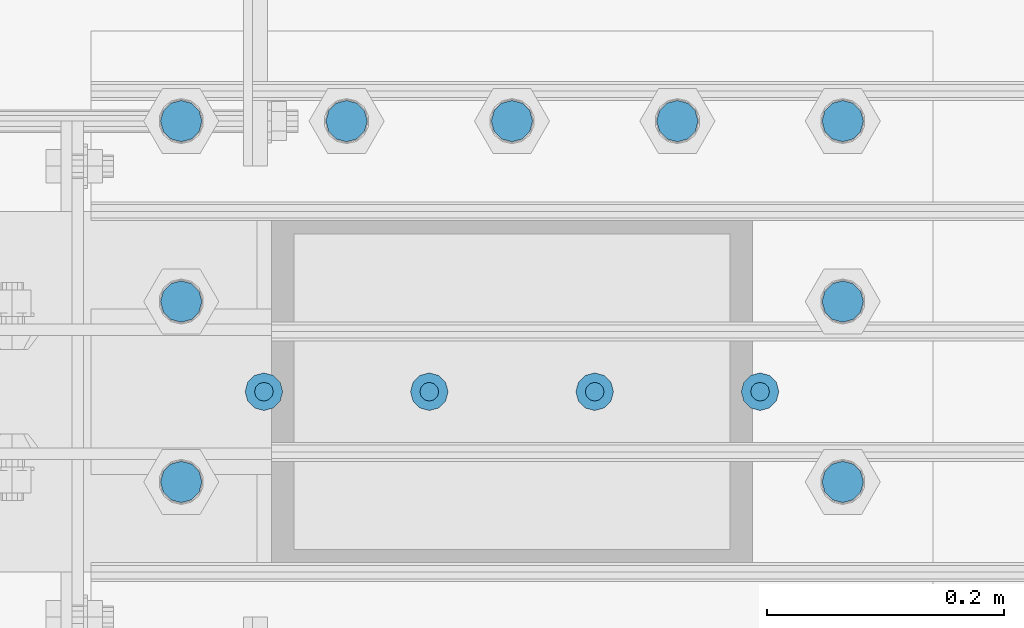
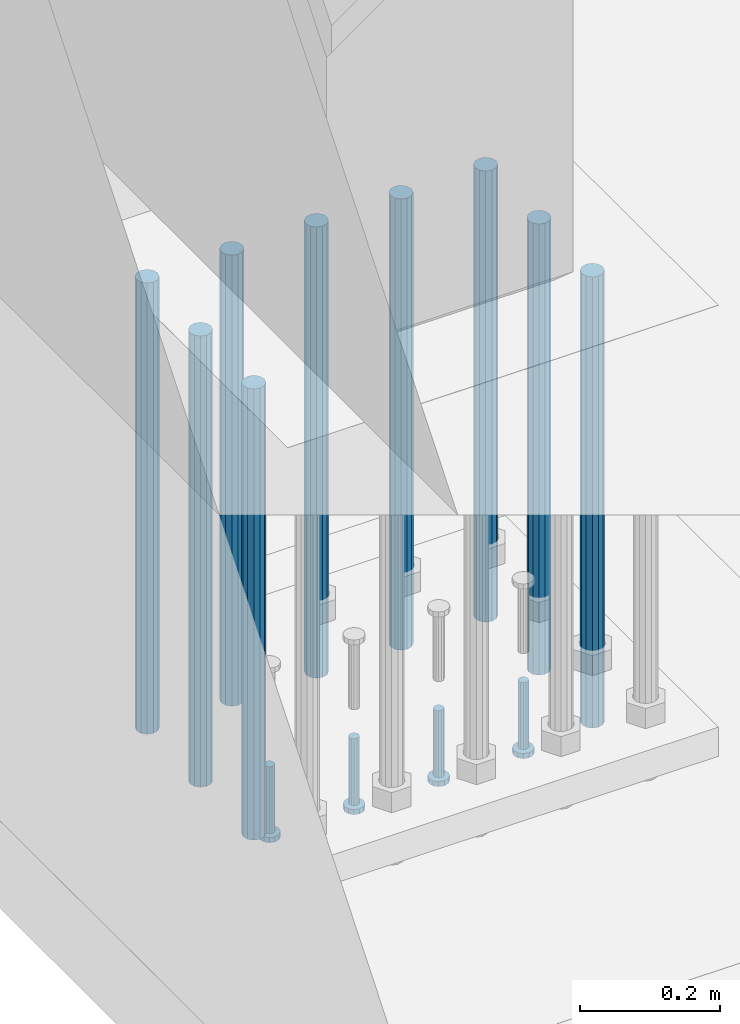
# One storey, part 1106 of 1876: 13 beams, 1 element without a shape of its own.
"""IFC2X3 building model written with IfcOpenShell, lengths in millimetres."""

import ifcopenshell
import ifcopenshell.guid

model = None  # the IFC model being written
_history = None  # IfcOwnerHistory: only IFC2X3 demands one
_inside = {}  # id of a spatial element -> (the spatial element, [elements in it])
_under = {}  # id of a project, library or spatial element -> (it, [spatial elements below it])
_declared = {}  # id of a project -> (the project, [libraries it declares])
_typed = {}  # id of a type object -> (the type object, [elements of that type])
_made_of = {}  # id of a material, layer set ... -> (it, [elements and type objects made of it])


def new_model(schema):
    """Start an empty IFC model of exactly this schema.

    Asked for "IFC4X3", IfcOpenShell would pick the latest addendum, in which some entities
    have other attributes; the version numbers below select the first issue.
    IFC2X3 requires an IfcOwnerHistory on every rooted entity: one is made here for all.
    """
    global model, _history
    if schema == "IFC4X3":
        model = ifcopenshell.file(schema_version=(4, 3, 0, 0))
    else:
        model = ifcopenshell.file(schema=schema)
    _inside.clear()
    _under.clear()
    _declared.clear()
    _typed.clear()
    _made_of.clear()
    _history = None
    if model.schema == "IFC2X3":
        org = make("IfcOrganization", Name="unknown")
        user = make(
            "IfcPersonAndOrganization",
            ThePerson=make("IfcPerson", FamilyName="unknown"),
            TheOrganization=org,
        )
        app = make(
            "IfcApplication",
            ApplicationDeveloper=org,
            Version="unknown",
            ApplicationFullName="unknown",
            ApplicationIdentifier="unknown",
        )
        _history = make(
            "IfcOwnerHistory",
            OwningUser=user,
            OwningApplication=app,
            ChangeAction="ADDED",
            CreationDate=0,
        )
    return model


def make(cls, **values):
    """One entity of the class cls with the attributes given. An attribute that is None is left unset."""
    return model.create_entity(
        cls, **{name: value for name, value in values.items() if value is not None}
    )


def rooted(cls, **values):
    """An entity with a GlobalId (a new one), such as an element, a storey or a relation."""
    return make(cls, GlobalId=ifcopenshell.guid.new(), OwnerHistory=_history, **values)


def si_unit(unit_type, name, prefix=None):
    """IfcSIUnit, for example si_unit("LENGTHUNIT", "METRE", prefix="MILLI")."""
    return make("IfcSIUnit", UnitType=unit_type, Prefix=prefix, Name=name)


def assignment(units):
    """IfcUnitAssignment: the units of a project."""
    return None if units is None else make("IfcUnitAssignment", Units=units)


def point(xyz):
    """IfcCartesianPoint."""
    return None if xyz is None else make("IfcCartesianPoint", Coordinates=xyz)


def direction(xyz):
    """IfcDirection."""
    return None if xyz is None else make("IfcDirection", DirectionRatios=xyz)


def frame(location, z_axis=None, x_axis=None):
    """IfcAxis2Placement3D, a coordinate frame: its origin and axes. An axis left out is left unset."""
    return make(
        "IfcAxis2Placement3D",
        Location=point(location),
        Axis=direction(z_axis),
        RefDirection=direction(x_axis),
    )


def origin_with_axes():
    """The frame at (0, 0, 0) with the z axis (0, 0, 1) and the x axis (1, 0, 0) written out."""
    return frame((0.0, 0.0, 0.0), z_axis=(0.0, 0.0, 1.0), x_axis=(1.0, 0.0, 0.0))


def place(relative_to, where):
    """IfcLocalPlacement: puts the frame where relative to a parent placement (None: the world)."""
    return make(
        "IfcLocalPlacement", PlacementRelTo=relative_to, RelativePlacement=where
    )


def context(
    kind, dimensions, precision=None, world=None, true_north=None, identifier=None
):
    """IfcGeometricRepresentationContext, for example the 3D "Model" context."""
    return make(
        "IfcGeometricRepresentationContext",
        ContextIdentifier=identifier,
        ContextType=kind,
        CoordinateSpaceDimension=dimensions,
        Precision=precision,
        WorldCoordinateSystem=world,
        TrueNorth=true_north,
    )


def subcontext(parent, identifier, kind, view, scale=None):
    """IfcGeometricRepresentationSubContext, for example "Body" below "Model"."""
    return make(
        "IfcGeometricRepresentationSubContext",
        ContextIdentifier=identifier,
        ContextType=kind,
        ParentContext=parent,
        TargetScale=scale,
        TargetView=view,
    )


def project(units=None, contexts=None):
    """IfcProject with its units and contexts."""
    return rooted(
        "IfcProject",
        Name="project",
        RepresentationContexts=contexts,
        UnitsInContext=assignment(units),
    )


def spatial(cls, under=None, at=None, **own):
    """A site, building, storey or space (cls), placed at a placement, below another one or the project."""
    s = rooted(cls, ObjectPlacement=at, **own)
    if under is not None:
        _under.setdefault(under.id(), (under, []))[1].append(s)
    return s


def faces_of(points, faces, orient=None, outer=None):
    """IfcFace entities. A face is a list of loops; a loop is a list of indices into points, from 0.

    orient and outer hold one flag for each loop. By default every Orientation is true, the
    first loop of a face is its IfcFaceOuterBound and the others are IfcFaceBound.
    """
    made = []
    for i, loops in enumerate(faces):
        bounds = []
        for j, loop in enumerate(loops):
            is_outer = j == 0 if outer is None else outer[i][j]
            bounds.append(
                make(
                    "IfcFaceOuterBound" if is_outer else "IfcFaceBound",
                    Bound=make("IfcPolyLoop", Polygon=[points[k] for k in loop]),
                    Orientation=True if orient is None else orient[i][j],
                )
            )
        made.append(make("IfcFace", Bounds=bounds))
    return made


def faceted_brep(points, faces, orient=None, outer=None, voids=None):
    """IfcFacetedBrep: a solid bounded by flat faces; with voids (closed shells), ...WithVoids."""
    shared = [point(p) for p in points]
    hull = make("IfcClosedShell", CfsFaces=faces_of(shared, faces, orient, outer))
    if voids is None:
        return make("IfcFacetedBrep", Outer=hull)
    return make(
        "IfcFacetedBrepWithVoids",
        Outer=hull,
        Voids=[
            make(cls, CfsFaces=faces_of(shared, fs, o, b)) for cls, fs, o, b in voids
        ],
    )


def shape(context_of_items, identifier, shape_type, items):
    """IfcShapeRepresentation: the items that make up one representation, for example the "Body"."""
    return make(
        "IfcShapeRepresentation",
        ContextOfItems=context_of_items,
        RepresentationIdentifier=identifier,
        RepresentationType=shape_type,
        Items=items,
    )


def material(Name=None, Category=None):
    """IfcMaterial."""
    return make("IfcMaterial", Name=Name, Category=Category)


def made_of(thing, what):
    """Note that an element or type object is made of a material, layer set ...; save() writes the relation."""
    if what is not None:
        _made_of.setdefault(what.id(), (what, []))[1].append(thing)
    return thing


def type_object(cls, material=None, **own):
    """A type object (cls), such as IfcWallType, which elements share."""
    return made_of(rooted(cls, **own), material)


def element(
    cls,
    number,
    at=None,
    inside=None,
    cuts=None,
    type_object=None,
    material=None,
    context=None,
    identifier="Body",
    shape_type=None,
    held_by="IfcProductDefinitionShape",
    body=None,
    shapes=None,
    **own,
):
    """One element of the class cls, such as IfcWall. Its Tag is "e" and its number.

    at: its placement. inside: the storey or other place that contains it. cuts: it is an
    opening in that element (IfcRelVoidsElement). A single representation is given by context,
    identifier, shape_type and body (its items); several are given by shapes. held_by: the class
    of the entity that holds the representations. save() writes the other relations.
    """
    e = rooted(cls, Tag="e%d" % number, ObjectPlacement=at, **own)
    if body is not None:
        shapes = [shape(context, identifier, shape_type, body)]
    if shapes is not None:
        e.Representation = make(held_by, Representations=shapes)
    if inside is not None:
        _inside.setdefault(inside.id(), (inside, []))[1].append(e)
    if cuts is not None:
        rooted(
            "IfcRelVoidsElement", RelatingBuildingElement=cuts, RelatedOpeningElement=e
        )
    if type_object is not None:
        _typed.setdefault(type_object.id(), (type_object, []))[1].append(e)
    return made_of(e, material)


def aggregate(whole, parts):
    """IfcRelAggregates: a whole, such as a stair, and the parts it consists of."""
    return rooted("IfcRelAggregates", RelatingObject=whole, RelatedObjects=parts)


def save(model, path):
    """Write the relations noted so far, then the file.

    IfcRelAggregates (storeys below a building ...), IfcRelContainedInSpatialStructure (elements
    in a storey), IfcRelDefinesByType, IfcRelAssociatesMaterial and IfcRelDeclares: one each for
    every whole, place, type object, material and project.
    """
    for whole, parts in _under.values():
        aggregate(whole, parts)
    for where, things in _inside.values():
        rooted(
            "IfcRelContainedInSpatialStructure",
            RelatedElements=things,
            RelatingStructure=where,
        )
    for kind, things in _typed.values():
        rooted("IfcRelDefinesByType", RelatedObjects=things, RelatingType=kind)
    for what, things in _made_of.values():
        rooted("IfcRelAssociatesMaterial", RelatedObjects=things, RelatingMaterial=what)
    for by, libraries in _declared.values():
        rooted("IfcRelDeclares", RelatingContext=by, RelatedDefinitions=libraries)
    model.write(path)


model = new_model("IFC2X3")

# Units and contexts
model_context = context("Model", 3, precision=1e-05, world=origin_with_axes())
body_context = subcontext(model_context, "Body", "Model", "MODEL_VIEW")
ifc_project = project(units=[si_unit("LENGTHUNIT", "METRE", prefix="MILLI"), si_unit("AREAUNIT", "SQUARE_METRE"), si_unit("VOLUMEUNIT", "CUBIC_METRE"), si_unit("MASSUNIT", "GRAM", prefix="KILO"), si_unit("TIMEUNIT", "SECOND"), si_unit("PLANEANGLEUNIT", "RADIAN"), si_unit("SOLIDANGLEUNIT", "STERADIAN"), si_unit("THERMODYNAMICTEMPERATUREUNIT", "DEGREE_CELSIUS"), si_unit("LUMINOUSINTENSITYUNIT", "LUMEN")], contexts=[model_context])

# Site, building, storey
site_placement = place(None, origin_with_axes())
site = spatial("IfcSite", under=ifc_project, at=site_placement, CompositionType="ELEMENT")
building_placement = place(site_placement, origin_with_axes())
building = spatial("IfcBuilding", under=site, at=building_placement, Name="Undefined", CompositionType="ELEMENT")
storey_placement = place(building_placement, origin_with_axes())
storey = spatial("IfcBuildingStorey", under=building, at=storey_placement, Name="Undefined", CompositionType="ELEMENT", Elevation=0.0)

# Assembly, beams
assembly_placement = place(storey_placement, origin_with_axes())
assembly = element("IfcElementAssembly", 1, at=assembly_placement, inside=storey, Name="PLATE", AssemblyPlace="NOTDEFINED", PredefinedType="RIGID_FRAME")
ifc_material_1 = material(Name="STEEL/A108")
beam_type_1 = type_object("IfcBeamType", Name="5/8-DIA_HEADED ANCHOR STUD", PredefinedType="NOTDEFINED")
beam_1_placement = place(assembly_placement, frame((441.324993896484, -10769.6, -787.4), z_axis=(1.0, 0.0, 0.0), x_axis=(0.0, 0.0, -1.0)))
beam_1 = element("IfcBeam", 2, at=beam_1_placement, type_object=beam_type_1, material=ifc_material_1, Name="HEADED ANCHOR STUD", ObjectType="5/8-DIA_HEADED ANCHOR STUD", context=body_context, shape_type="Brep", body=[
    faceted_brep([(0.0, -7.94000005722046, 0.0), (0.0, -6.86999988555908, -3.97000002861023), (116.84, -6.86999988555908, -3.97000002861023), (116.84, -7.94000005722046, 0.0), (0.0, -3.97000002861023, -6.86999988555908), (116.84, -3.97000002861023, -6.86999988555908), (0.0, 0.0, -7.94000005722046), (116.84, 0.0, -7.94000005722046), (0.0, 3.97000002861023, -6.86999988555908), (116.84, 3.97000002861023, -6.86999988555908), (0.0, 6.86999988555908, -3.97000002861023), (116.84, 6.86999988555908, -3.97000002861023), (0.0, 7.94000005722046, 0.0), (116.84, 7.94000005722046, 0.0), (0.0, 6.86999988555908, 3.97000002861023), (116.84, 6.86999988555908, 3.97000002861023), (0.0, 3.97000002861023, 6.86999988555908), (116.84, 3.97000002861023, 6.86999988555908), (0.0, 0.0, 7.94000005722046), (116.84, 0.0, 7.94000005722046), (0.0, -3.97000002861023, 6.86999988555908), (116.84, -3.97000002861023, 6.86999988555908), (0.0, -6.86999988555908, 3.97000002861023), (116.84, -6.86999988555908, 3.97000002861023), (118.11, -13.75, -7.94000005722046), (118.11, -15.8800001144409, 0.0), (118.11, -7.94000005722046, -13.75), (118.11, 0.0, -15.8800001144409), (118.11, 7.94000005722046, -13.75), (118.11, 13.75, -7.94000005722046), (118.11, 15.8800001144409, 0.0), (118.11, 13.75, 7.94000005722046), (118.11, 7.94000005722046, 13.75), (118.11, 0.0, 15.8800001144409), (118.11, -7.94000005722046, 13.75), (118.11, -13.75, 7.94000005722046), (127.0, -13.75, -7.94000005722046), (127.0, -15.8800001144409, 0.0), (127.0, -7.94000005722046, -13.75), (127.0, 0.0, -15.8800001144409), (127.0, 7.94000005722046, -13.75), (127.0, 13.75, -7.94000005722046), (127.0, 15.8800001144409, 0.0), (127.0, 13.75, 7.94000005722046), (127.0, 7.94000005722046, 13.75), (127.0, 0.0, 15.8800001144409), (127.0, -7.94000005722046, 13.75), (127.0, -13.75, 7.94000005722046)], [[[0, 1, 2, 3]], [[1, 4, 5, 2]], [[4, 6, 7, 5]], [[6, 8, 9, 7]], [[8, 10, 11, 9]], [[10, 12, 13, 11]], [[12, 14, 15, 13]], [[14, 16, 17, 15]], [[16, 18, 19, 17]], [[18, 20, 21, 19]], [[20, 22, 23, 21]], [[22, 0, 3, 23]], [[22, 20, 18, 16, 14, 12, 10, 8, 6, 4, 1, 0]], [[3, 2, 24, 25]], [[2, 5, 26, 24]], [[5, 7, 27, 26]], [[7, 9, 28, 27]], [[9, 11, 29, 28]], [[11, 13, 30, 29]], [[13, 15, 31, 30]], [[15, 17, 32, 31]], [[17, 19, 33, 32]], [[19, 21, 34, 33]], [[21, 23, 35, 34]], [[23, 3, 25, 35]], [[25, 24, 36, 37]], [[24, 26, 38, 36]], [[26, 27, 39, 38]], [[27, 28, 40, 39]], [[28, 29, 41, 40]], [[29, 30, 42, 41]], [[30, 31, 43, 42]], [[31, 32, 44, 43]], [[32, 33, 45, 44]], [[33, 34, 46, 45]], [[34, 35, 47, 46]], [[35, 25, 37, 47]], [[38, 39, 40, 41, 42, 43, 44, 45, 46, 47, 37, 36]]]),
])
beam_2_placement = place(assembly_placement, frame((301.624987792969, -10769.6, -787.4), z_axis=(1.0, 0.0, 0.0), x_axis=(0.0, 0.0, -1.0)))
beam_2 = element("IfcBeam", 3, at=beam_2_placement, type_object=beam_type_1, material=ifc_material_1, Name="HEADED ANCHOR STUD", ObjectType="5/8-DIA_HEADED ANCHOR STUD", context=body_context, shape_type="Brep", body=[
    faceted_brep([(0.0, -7.94000005722046, 0.0), (0.0, -6.86999988555908, -3.97000002861023), (116.84, -6.86999988555908, -3.97000002861023), (116.84, -7.94000005722046, 0.0), (0.0, -3.97000002861023, -6.86999988555908), (116.84, -3.97000002861023, -6.86999988555908), (0.0, 0.0, -7.94000005722046), (116.84, 0.0, -7.94000005722046), (0.0, 3.97000002861023, -6.86999988555908), (116.84, 3.97000002861023, -6.86999988555908), (0.0, 6.86999988555908, -3.97000002861023), (116.84, 6.86999988555908, -3.97000002861023), (0.0, 7.94000005722046, 0.0), (116.84, 7.94000005722046, 0.0), (0.0, 6.86999988555908, 3.97000002861023), (116.84, 6.86999988555908, 3.97000002861023), (0.0, 3.97000002861023, 6.86999988555908), (116.84, 3.97000002861023, 6.86999988555908), (0.0, 0.0, 7.94000005722046), (116.84, 0.0, 7.94000005722046), (0.0, -3.97000002861023, 6.86999988555908), (116.84, -3.97000002861023, 6.86999988555908), (0.0, -6.86999988555908, 3.97000002861023), (116.84, -6.86999988555908, 3.97000002861023), (118.11, -13.75, -7.94000005722046), (118.11, -15.8800001144409, 0.0), (118.11, -7.94000005722046, -13.75), (118.11, 0.0, -15.8800001144409), (118.11, 7.94000005722046, -13.75), (118.11, 13.75, -7.94000005722046), (118.11, 15.8800001144409, 0.0), (118.11, 13.75, 7.94000005722046), (118.11, 7.94000005722046, 13.75), (118.11, 0.0, 15.8800001144409), (118.11, -7.94000005722046, 13.75), (118.11, -13.75, 7.94000005722046), (127.0, -13.75, -7.94000005722046), (127.0, -15.8800001144409, 0.0), (127.0, -7.94000005722046, -13.75), (127.0, 0.0, -15.8800001144409), (127.0, 7.94000005722046, -13.75), (127.0, 13.75, -7.94000005722046), (127.0, 15.8800001144409, 0.0), (127.0, 13.75, 7.94000005722046), (127.0, 7.94000005722046, 13.75), (127.0, 0.0, 15.8800001144409), (127.0, -7.94000005722046, 13.75), (127.0, -13.75, 7.94000005722046)], [[[0, 1, 2, 3]], [[1, 4, 5, 2]], [[4, 6, 7, 5]], [[6, 8, 9, 7]], [[8, 10, 11, 9]], [[10, 12, 13, 11]], [[12, 14, 15, 13]], [[14, 16, 17, 15]], [[16, 18, 19, 17]], [[18, 20, 21, 19]], [[20, 22, 23, 21]], [[22, 0, 3, 23]], [[22, 20, 18, 16, 14, 12, 10, 8, 6, 4, 1, 0]], [[3, 2, 24, 25]], [[2, 5, 26, 24]], [[5, 7, 27, 26]], [[7, 9, 28, 27]], [[9, 11, 29, 28]], [[11, 13, 30, 29]], [[13, 15, 31, 30]], [[15, 17, 32, 31]], [[17, 19, 33, 32]], [[19, 21, 34, 33]], [[21, 23, 35, 34]], [[23, 3, 25, 35]], [[25, 24, 36, 37]], [[24, 26, 38, 36]], [[26, 27, 39, 38]], [[27, 28, 40, 39]], [[28, 29, 41, 40]], [[29, 30, 42, 41]], [[30, 31, 43, 42]], [[31, 32, 44, 43]], [[32, 33, 45, 44]], [[33, 34, 46, 45]], [[34, 35, 47, 46]], [[35, 25, 37, 47]], [[38, 39, 40, 41, 42, 43, 44, 45, 46, 47, 37, 36]]]),
])
beam_3_placement = place(assembly_placement, frame((161.924987792969, -10769.6, -787.4), z_axis=(1.0, 0.0, 0.0), x_axis=(0.0, 0.0, -1.0)))
beam_3 = element("IfcBeam", 4, at=beam_3_placement, type_object=beam_type_1, material=ifc_material_1, Name="HEADED ANCHOR STUD", ObjectType="5/8-DIA_HEADED ANCHOR STUD", context=body_context, shape_type="Brep", body=[
    faceted_brep([(0.0, -7.94000005722046, 0.0), (0.0, -6.86999988555908, -3.97000002861023), (116.84, -6.86999988555908, -3.97000002861023), (116.84, -7.94000005722046, 0.0), (0.0, -3.97000002861023, -6.86999988555908), (116.84, -3.97000002861023, -6.86999988555908), (0.0, 0.0, -7.94000005722046), (116.84, 0.0, -7.94000005722046), (0.0, 3.97000002861023, -6.86999988555908), (116.84, 3.97000002861023, -6.86999988555908), (0.0, 6.86999988555908, -3.97000002861023), (116.84, 6.86999988555908, -3.97000002861023), (0.0, 7.94000005722046, 0.0), (116.84, 7.94000005722046, 0.0), (0.0, 6.86999988555908, 3.97000002861023), (116.84, 6.86999988555908, 3.97000002861023), (0.0, 3.97000002861023, 6.86999988555908), (116.84, 3.97000002861023, 6.86999988555908), (0.0, 0.0, 7.94000005722046), (116.84, 0.0, 7.94000005722046), (0.0, -3.97000002861023, 6.86999988555908), (116.84, -3.97000002861023, 6.86999988555908), (0.0, -6.86999988555908, 3.97000002861023), (116.84, -6.86999988555908, 3.97000002861023), (118.11, -13.75, -7.94000005722046), (118.11, -15.8800001144409, 0.0), (118.11, -7.94000005722046, -13.75), (118.11, 0.0, -15.8800001144409), (118.11, 7.94000005722046, -13.75), (118.11, 13.75, -7.94000005722046), (118.11, 15.8800001144409, 0.0), (118.11, 13.75, 7.94000005722046), (118.11, 7.94000005722046, 13.75), (118.11, 0.0, 15.8800001144409), (118.11, -7.94000005722046, 13.75), (118.11, -13.75, 7.94000005722046), (127.0, -13.75, -7.94000005722046), (127.0, -15.8800001144409, 0.0), (127.0, -7.94000005722046, -13.75), (127.0, 0.0, -15.8800001144409), (127.0, 7.94000005722046, -13.75), (127.0, 13.75, -7.94000005722046), (127.0, 15.8800001144409, 0.0), (127.0, 13.75, 7.94000005722046), (127.0, 7.94000005722046, 13.75), (127.0, 0.0, 15.8800001144409), (127.0, -7.94000005722046, 13.75), (127.0, -13.75, 7.94000005722046)], [[[0, 1, 2, 3]], [[1, 4, 5, 2]], [[4, 6, 7, 5]], [[6, 8, 9, 7]], [[8, 10, 11, 9]], [[10, 12, 13, 11]], [[12, 14, 15, 13]], [[14, 16, 17, 15]], [[16, 18, 19, 17]], [[18, 20, 21, 19]], [[20, 22, 23, 21]], [[22, 0, 3, 23]], [[22, 20, 18, 16, 14, 12, 10, 8, 6, 4, 1, 0]], [[3, 2, 24, 25]], [[2, 5, 26, 24]], [[5, 7, 27, 26]], [[7, 9, 28, 27]], [[9, 11, 29, 28]], [[11, 13, 30, 29]], [[13, 15, 31, 30]], [[15, 17, 32, 31]], [[17, 19, 33, 32]], [[19, 21, 34, 33]], [[21, 23, 35, 34]], [[23, 3, 25, 35]], [[25, 24, 36, 37]], [[24, 26, 38, 36]], [[26, 27, 39, 38]], [[27, 28, 40, 39]], [[28, 29, 41, 40]], [[29, 30, 42, 41]], [[30, 31, 43, 42]], [[31, 32, 44, 43]], [[32, 33, 45, 44]], [[33, 34, 46, 45]], [[34, 35, 47, 46]], [[35, 25, 37, 47]], [[38, 39, 40, 41, 42, 43, 44, 45, 46, 47, 37, 36]]]),
])
beam_4_placement = place(assembly_placement, frame((22.2249877929689, -10769.6, -787.4), z_axis=(1.0, 0.0, 0.0), x_axis=(0.0, 0.0, -1.0)))
beam_4 = element("IfcBeam", 5, at=beam_4_placement, type_object=beam_type_1, material=ifc_material_1, Name="HEADED ANCHOR STUD", ObjectType="5/8-DIA_HEADED ANCHOR STUD", context=body_context, shape_type="Brep", body=[
    faceted_brep([(0.0, -7.94000005722046, 0.0), (0.0, -6.86999988555908, -3.97000002861023), (116.84, -6.86999988555908, -3.97000002861023), (116.84, -7.94000005722046, 0.0), (0.0, -3.97000002861023, -6.86999988555908), (116.84, -3.97000002861023, -6.86999988555908), (0.0, 0.0, -7.94000005722046), (116.84, 0.0, -7.94000005722046), (0.0, 3.97000002861023, -6.86999988555908), (116.84, 3.97000002861023, -6.86999988555908), (0.0, 6.86999988555908, -3.97000002861023), (116.84, 6.86999988555908, -3.97000002861023), (0.0, 7.94000005722046, 0.0), (116.84, 7.94000005722046, 0.0), (0.0, 6.86999988555908, 3.97000002861023), (116.84, 6.86999988555908, 3.97000002861023), (0.0, 3.97000002861023, 6.86999988555908), (116.84, 3.97000002861023, 6.86999988555908), (0.0, 0.0, 7.94000005722046), (116.84, 0.0, 7.94000005722046), (0.0, -3.97000002861023, 6.86999988555908), (116.84, -3.97000002861023, 6.86999988555908), (0.0, -6.86999988555908, 3.97000002861023), (116.84, -6.86999988555908, 3.97000002861023), (118.11, -13.75, -7.94000005722046), (118.11, -15.8800001144409, 0.0), (118.11, -7.94000005722046, -13.75), (118.11, 0.0, -15.8800001144409), (118.11, 7.94000005722046, -13.75), (118.11, 13.75, -7.94000005722046), (118.11, 15.8800001144409, 0.0), (118.11, 13.75, 7.94000005722046), (118.11, 7.94000005722046, 13.75), (118.11, 0.0, 15.8800001144409), (118.11, -7.94000005722046, 13.75), (118.11, -13.75, 7.94000005722046), (127.0, -13.75, -7.94000005722046), (127.0, -15.8800001144409, 0.0), (127.0, -7.94000005722046, -13.75), (127.0, 0.0, -15.8800001144409), (127.0, 7.94000005722046, -13.75), (127.0, 13.75, -7.94000005722046), (127.0, 15.8800001144409, 0.0), (127.0, 13.75, 7.94000005722046), (127.0, 7.94000005722046, 13.75), (127.0, 0.0, 15.8800001144409), (127.0, -7.94000005722046, 13.75), (127.0, -13.75, 7.94000005722046)], [[[0, 1, 2, 3]], [[1, 4, 5, 2]], [[4, 6, 7, 5]], [[6, 8, 9, 7]], [[8, 10, 11, 9]], [[10, 12, 13, 11]], [[12, 14, 15, 13]], [[14, 16, 17, 15]], [[16, 18, 19, 17]], [[18, 20, 21, 19]], [[20, 22, 23, 21]], [[22, 0, 3, 23]], [[22, 20, 18, 16, 14, 12, 10, 8, 6, 4, 1, 0]], [[3, 2, 24, 25]], [[2, 5, 26, 24]], [[5, 7, 27, 26]], [[7, 9, 28, 27]], [[9, 11, 29, 28]], [[11, 13, 30, 29]], [[13, 15, 31, 30]], [[15, 17, 32, 31]], [[17, 19, 33, 32]], [[19, 21, 34, 33]], [[21, 23, 35, 34]], [[23, 3, 25, 35]], [[25, 24, 36, 37]], [[24, 26, 38, 36]], [[26, 27, 39, 38]], [[27, 28, 40, 39]], [[28, 29, 41, 40]], [[29, 30, 42, 41]], [[30, 31, 43, 42]], [[31, 32, 44, 43]], [[32, 33, 45, 44]], [[33, 34, 46, 45]], [[34, 35, 47, 46]], [[35, 25, 37, 47]], [[38, 39, 40, 41, 42, 43, 44, 45, 46, 47, 37, 36]]]),
])
ifc_material_2 = material(Name="STEEL/F1554-55, S1")
beam_type_2 = type_object("IfcBeamType", PredefinedType="NOTDEFINED")
beam_5_placement = place(assembly_placement, frame((371.474987792969, -10541.0, -50.7999999999999), z_axis=(0.0, -1.0, 0.0), x_axis=(0.0, 0.0, -1.0)))
beam_5 = element("IfcBeam", 6, at=beam_5_placement, type_object=beam_type_2, material=ifc_material_2, Name="WELDED HEADED STUD", context=body_context, shape_type="Brep", body=[
    faceted_brep([(0.0, -17.4625, 0.0), (0.0, -15.1229686135857, -8.73125000000073), (787.399999999999, -15.1229686135857, -8.73125000000073), (787.399999999999, -17.4625, 0.0), (0.0, -8.73124999999999, -15.1229686135848), (787.399999999999, -8.73124999999999, -15.1229686135848), (0.0, 0.0, -17.4625000000015), (787.399999999999, 0.0, -17.4625000000015), (0.0, 8.73124999999999, -15.1229686135848), (787.399999999999, 8.73124999999999, -15.1229686135848), (0.0, 15.1229686135858, -8.73125000000073), (787.399999999999, 15.1229686135858, -8.73125000000073), (0.0, 17.4625, 0.0), (787.399999999999, 17.4625, 0.0), (0.0, 15.1229686135858, 8.73125000000073), (787.399999999999, 15.1229686135858, 8.73125000000073), (0.0, 8.73124999999999, 15.1229686135848), (787.399999999999, 8.73124999999999, 15.1229686135848), (0.0, 0.0, 17.4625000000015), (787.399999999999, 0.0, 17.4625000000015), (0.0, -8.73124999999999, 15.1229686135848), (787.399999999999, -8.73124999999999, 15.1229686135848), (0.0, -15.1229686135858, 8.73125000000073), (787.399999999999, -15.1229686135858, 8.73125000000073)], [[[0, 1, 2, 3]], [[1, 4, 5, 2]], [[4, 6, 7, 5]], [[6, 8, 9, 7]], [[8, 10, 11, 9]], [[10, 12, 13, 11]], [[12, 14, 15, 13]], [[14, 16, 17, 15]], [[16, 18, 19, 17]], [[18, 20, 21, 19]], [[20, 22, 23, 21]], [[22, 0, 3, 23]], [[5, 7, 9, 11, 13, 15, 17, 19, 21, 23, 3, 2]], [[22, 20, 18, 16, 14, 12, 10, 8, 6, 4, 1, 0]]]),
])
beam_6_placement = place(assembly_placement, frame((231.774987792969, -10541.0, -50.7999999999999), z_axis=(0.0, -1.0, 0.0), x_axis=(0.0, 0.0, -1.0)))
beam_6 = element("IfcBeam", 7, at=beam_6_placement, type_object=beam_type_2, material=ifc_material_2, Name="WELDED HEADED STUD", context=body_context, shape_type="Brep", body=[
    faceted_brep([(0.0, -17.4625, 0.0), (0.0, -15.1229686135857, -8.73125000000073), (787.399999999999, -15.1229686135857, -8.73125000000073), (787.399999999999, -17.4625, 0.0), (0.0, -8.73124999999999, -15.1229686135848), (787.399999999999, -8.73124999999999, -15.1229686135848), (0.0, 0.0, -17.4625000000015), (787.399999999999, 0.0, -17.4625000000015), (0.0, 8.73124999999999, -15.1229686135848), (787.399999999999, 8.73124999999999, -15.1229686135848), (0.0, 15.1229686135858, -8.73125000000073), (787.399999999999, 15.1229686135858, -8.73125000000073), (0.0, 17.4625, 0.0), (787.399999999999, 17.4625, 0.0), (0.0, 15.1229686135858, 8.73125000000073), (787.399999999999, 15.1229686135858, 8.73125000000073), (0.0, 8.73124999999999, 15.1229686135848), (787.399999999999, 8.73124999999999, 15.1229686135848), (0.0, 0.0, 17.4625000000015), (787.399999999999, 0.0, 17.4625000000015), (0.0, -8.73124999999999, 15.1229686135848), (787.399999999999, -8.73124999999999, 15.1229686135848), (0.0, -15.1229686135858, 8.73125000000073), (787.399999999999, -15.1229686135858, 8.73125000000073)], [[[0, 1, 2, 3]], [[1, 4, 5, 2]], [[4, 6, 7, 5]], [[6, 8, 9, 7]], [[8, 10, 11, 9]], [[10, 12, 13, 11]], [[12, 14, 15, 13]], [[14, 16, 17, 15]], [[16, 18, 19, 17]], [[18, 20, 21, 19]], [[20, 22, 23, 21]], [[22, 0, 3, 23]], [[5, 7, 9, 11, 13, 15, 17, 19, 21, 23, 3, 2]], [[22, 20, 18, 16, 14, 12, 10, 8, 6, 4, 1, 0]]]),
])
beam_7_placement = place(assembly_placement, frame((92.074987792969, -10541.0, -50.7999999999999), z_axis=(0.0, -1.0, 0.0), x_axis=(0.0, 0.0, -1.0)))
beam_7 = element("IfcBeam", 8, at=beam_7_placement, type_object=beam_type_2, material=ifc_material_2, Name="WELDED HEADED STUD", context=body_context, shape_type="Brep", body=[
    faceted_brep([(0.0, -17.4625, 0.0), (0.0, -15.1229686135857, -8.73125000000073), (787.399999999999, -15.1229686135857, -8.73125000000073), (787.399999999999, -17.4625, 0.0), (0.0, -8.73124999999999, -15.1229686135848), (787.399999999999, -8.73124999999999, -15.1229686135848), (0.0, 0.0, -17.4625000000015), (787.399999999999, 0.0, -17.4625000000015), (0.0, 8.73124999999999, -15.1229686135848), (787.399999999999, 8.73124999999999, -15.1229686135848), (0.0, 15.1229686135858, -8.73125000000073), (787.399999999999, 15.1229686135858, -8.73125000000073), (0.0, 17.4625, 0.0), (787.399999999999, 17.4625, 0.0), (0.0, 15.1229686135858, 8.73125000000073), (787.399999999999, 15.1229686135858, 8.73125000000073), (0.0, 8.73124999999999, 15.1229686135848), (787.399999999999, 8.73124999999999, 15.1229686135848), (0.0, 0.0, 17.4625000000015), (787.399999999999, 0.0, 17.4625000000015), (0.0, -8.73124999999999, 15.1229686135848), (787.399999999999, -8.73124999999999, 15.1229686135848), (0.0, -15.1229686135858, 8.73125000000073), (787.399999999999, -15.1229686135858, 8.73125000000073)], [[[0, 1, 2, 3]], [[1, 4, 5, 2]], [[4, 6, 7, 5]], [[6, 8, 9, 7]], [[8, 10, 11, 9]], [[10, 12, 13, 11]], [[12, 14, 15, 13]], [[14, 16, 17, 15]], [[16, 18, 19, 17]], [[18, 20, 21, 19]], [[20, 22, 23, 21]], [[22, 0, 3, 23]], [[5, 7, 9, 11, 13, 15, 17, 19, 21, 23, 3, 2]], [[22, 20, 18, 16, 14, 12, 10, 8, 6, 4, 1, 0]]]),
])
beam_8_placement = place(assembly_placement, frame((-47.625012207031, -10693.399991862, -50.7999999999999), z_axis=(0.0, -1.0, 0.0), x_axis=(0.0, 0.0, -1.0)))
beam_8 = element("IfcBeam", 9, at=beam_8_placement, type_object=beam_type_2, material=ifc_material_2, Name="WELDED HEADED STUD", context=body_context, shape_type="Brep", body=[
    faceted_brep([(0.0, -17.4625, 0.0), (0.0, -15.1229686135857, -8.73125000000073), (787.399999999999, -15.1229686135857, -8.73125000000073), (787.399999999999, -17.4625, 0.0), (0.0, -8.73124999999999, -15.1229686135848), (787.399999999999, -8.73124999999999, -15.1229686135848), (0.0, 0.0, -17.4625000000015), (787.399999999999, 0.0, -17.4625000000015), (0.0, 8.73124999999999, -15.1229686135848), (787.399999999999, 8.73124999999999, -15.1229686135848), (0.0, 15.1229686135858, -8.73125000000073), (787.399999999999, 15.1229686135858, -8.73125000000073), (0.0, 17.4625, 0.0), (787.399999999999, 17.4625, 0.0), (0.0, 15.1229686135858, 8.73125000000073), (787.399999999999, 15.1229686135858, 8.73125000000073), (0.0, 8.73124999999999, 15.1229686135848), (787.399999999999, 8.73124999999999, 15.1229686135848), (0.0, 0.0, 17.4625000000015), (787.399999999999, 0.0, 17.4625000000015), (0.0, -8.73124999999999, 15.1229686135848), (787.399999999999, -8.73124999999999, 15.1229686135848), (0.0, -15.1229686135858, 8.73125000000073), (787.399999999999, -15.1229686135858, 8.73125000000073)], [[[0, 1, 2, 3]], [[1, 4, 5, 2]], [[4, 6, 7, 5]], [[6, 8, 9, 7]], [[8, 10, 11, 9]], [[10, 12, 13, 11]], [[12, 14, 15, 13]], [[14, 16, 17, 15]], [[16, 18, 19, 17]], [[18, 20, 21, 19]], [[20, 22, 23, 21]], [[22, 0, 3, 23]], [[5, 7, 9, 11, 13, 15, 17, 19, 21, 23, 3, 2]], [[22, 20, 18, 16, 14, 12, 10, 8, 6, 4, 1, 0]]]),
])
beam_9_placement = place(assembly_placement, frame((-47.625012207031, -10845.799983724, -50.7999999999999), z_axis=(0.0, -1.0, 0.0), x_axis=(0.0, 0.0, -1.0)))
beam_9 = element("IfcBeam", 10, at=beam_9_placement, type_object=beam_type_2, material=ifc_material_2, Name="WELDED HEADED STUD", context=body_context, shape_type="Brep", body=[
    faceted_brep([(0.0, -17.4625, 0.0), (0.0, -15.1229686135857, -8.73125000000073), (787.399999999999, -15.1229686135857, -8.73125000000073), (787.399999999999, -17.4625, 0.0), (0.0, -8.73124999999999, -15.1229686135848), (787.399999999999, -8.73124999999999, -15.1229686135848), (0.0, 0.0, -17.4625000000015), (787.399999999999, 0.0, -17.4625000000015), (0.0, 8.73124999999999, -15.1229686135848), (787.399999999999, 8.73124999999999, -15.1229686135848), (0.0, 15.1229686135858, -8.73125000000073), (787.399999999999, 15.1229686135858, -8.73125000000073), (0.0, 17.4625, 0.0), (787.399999999999, 17.4625, 0.0), (0.0, 15.1229686135858, 8.73125000000073), (787.399999999999, 15.1229686135858, 8.73125000000073), (0.0, 8.73124999999999, 15.1229686135848), (787.399999999999, 8.73124999999999, 15.1229686135848), (0.0, 0.0, 17.4625000000015), (787.399999999999, 0.0, 17.4625000000015), (0.0, -8.73124999999999, 15.1229686135848), (787.399999999999, -8.73124999999999, 15.1229686135848), (0.0, -15.1229686135858, 8.73125000000073), (787.399999999999, -15.1229686135858, 8.73125000000073)], [[[0, 1, 2, 3]], [[1, 4, 5, 2]], [[4, 6, 7, 5]], [[6, 8, 9, 7]], [[8, 10, 11, 9]], [[10, 12, 13, 11]], [[12, 14, 15, 13]], [[14, 16, 17, 15]], [[16, 18, 19, 17]], [[18, 20, 21, 19]], [[20, 22, 23, 21]], [[22, 0, 3, 23]], [[5, 7, 9, 11, 13, 15, 17, 19, 21, 23, 3, 2]], [[22, 20, 18, 16, 14, 12, 10, 8, 6, 4, 1, 0]]]),
])
beam_10_placement = place(assembly_placement, frame((-47.625012207031, -10541.0, -50.7999999999999), z_axis=(0.0, -1.0, 0.0), x_axis=(0.0, 0.0, -1.0)))
beam_10 = element("IfcBeam", 11, at=beam_10_placement, type_object=beam_type_2, material=ifc_material_2, Name="WELDED HEADED STUD", context=body_context, shape_type="Brep", body=[
    faceted_brep([(0.0, -17.4625, 0.0), (0.0, -15.1229686135857, -8.73125000000073), (787.399999999999, -15.1229686135857, -8.73125000000073), (787.399999999999, -17.4625, 0.0), (0.0, -8.73124999999999, -15.1229686135848), (787.399999999999, -8.73124999999999, -15.1229686135848), (0.0, 0.0, -17.4625000000015), (787.399999999999, 0.0, -17.4625000000015), (0.0, 8.73124999999999, -15.1229686135848), (787.399999999999, 8.73124999999999, -15.1229686135848), (0.0, 15.1229686135858, -8.73125000000073), (787.399999999999, 15.1229686135858, -8.73125000000073), (0.0, 17.4625, 0.0), (787.399999999999, 17.4625, 0.0), (0.0, 15.1229686135858, 8.73125000000073), (787.399999999999, 15.1229686135858, 8.73125000000073), (0.0, 8.73124999999999, 15.1229686135848), (787.399999999999, 8.73124999999999, 15.1229686135848), (0.0, 0.0, 17.4625000000015), (787.399999999999, 0.0, 17.4625000000015), (0.0, -8.73124999999999, 15.1229686135848), (787.399999999999, -8.73124999999999, 15.1229686135848), (0.0, -15.1229686135858, 8.73125000000073), (787.399999999999, -15.1229686135858, 8.73125000000073)], [[[0, 1, 2, 3]], [[1, 4, 5, 2]], [[4, 6, 7, 5]], [[6, 8, 9, 7]], [[8, 10, 11, 9]], [[10, 12, 13, 11]], [[12, 14, 15, 13]], [[14, 16, 17, 15]], [[16, 18, 19, 17]], [[18, 20, 21, 19]], [[20, 22, 23, 21]], [[22, 0, 3, 23]], [[5, 7, 9, 11, 13, 15, 17, 19, 21, 23, 3, 2]], [[22, 20, 18, 16, 14, 12, 10, 8, 6, 4, 1, 0]]]),
])
beam_11_placement = place(assembly_placement, frame((511.175, -10693.399991862, -50.7999999999999), z_axis=(0.0, -1.0, 0.0), x_axis=(0.0, 0.0, -1.0)))
beam_11 = element("IfcBeam", 12, at=beam_11_placement, type_object=beam_type_2, material=ifc_material_2, Name="WELDED HEADED STUD", context=body_context, shape_type="Brep", body=[
    faceted_brep([(0.0, -17.4625, 0.0), (0.0, -15.1229686135857, -8.73125000000073), (787.399999999999, -15.1229686135857, -8.73125000000073), (787.399999999999, -17.4625, 0.0), (0.0, -8.73124999999999, -15.1229686135848), (787.399999999999, -8.73124999999999, -15.1229686135848), (0.0, 0.0, -17.4625000000015), (787.399999999999, 0.0, -17.4625000000015), (0.0, 8.73124999999999, -15.1229686135848), (787.399999999999, 8.73124999999999, -15.1229686135848), (0.0, 15.1229686135858, -8.73125000000073), (787.399999999999, 15.1229686135858, -8.73125000000073), (0.0, 17.4625, 0.0), (787.399999999999, 17.4625, 0.0), (0.0, 15.1229686135858, 8.73125000000073), (787.399999999999, 15.1229686135858, 8.73125000000073), (0.0, 8.73124999999999, 15.1229686135848), (787.399999999999, 8.73124999999999, 15.1229686135848), (0.0, 0.0, 17.4625000000015), (787.399999999999, 0.0, 17.4625000000015), (0.0, -8.73124999999999, 15.1229686135848), (787.399999999999, -8.73124999999999, 15.1229686135848), (0.0, -15.1229686135858, 8.73125000000073), (787.399999999999, -15.1229686135858, 8.73125000000073)], [[[0, 1, 2, 3]], [[1, 4, 5, 2]], [[4, 6, 7, 5]], [[6, 8, 9, 7]], [[8, 10, 11, 9]], [[10, 12, 13, 11]], [[12, 14, 15, 13]], [[14, 16, 17, 15]], [[16, 18, 19, 17]], [[18, 20, 21, 19]], [[20, 22, 23, 21]], [[22, 0, 3, 23]], [[5, 7, 9, 11, 13, 15, 17, 19, 21, 23, 3, 2]], [[22, 20, 18, 16, 14, 12, 10, 8, 6, 4, 1, 0]]]),
])
beam_12_placement = place(assembly_placement, frame((511.175, -10845.799983724, -50.7999999999999), z_axis=(0.0, -1.0, 0.0), x_axis=(0.0, 0.0, -1.0)))
beam_12 = element("IfcBeam", 13, at=beam_12_placement, type_object=beam_type_2, material=ifc_material_2, Name="WELDED HEADED STUD", context=body_context, shape_type="Brep", body=[
    faceted_brep([(0.0, -17.4625, 0.0), (0.0, -15.1229686135857, -8.73125000000073), (787.399999999999, -15.1229686135857, -8.73125000000073), (787.399999999999, -17.4625, 0.0), (0.0, -8.73124999999999, -15.1229686135848), (787.399999999999, -8.73124999999999, -15.1229686135848), (0.0, 0.0, -17.4625000000015), (787.399999999999, 0.0, -17.4625000000015), (0.0, 8.73124999999999, -15.1229686135848), (787.399999999999, 8.73124999999999, -15.1229686135848), (0.0, 15.1229686135858, -8.73125000000073), (787.399999999999, 15.1229686135858, -8.73125000000073), (0.0, 17.4625, 0.0), (787.399999999999, 17.4625, 0.0), (0.0, 15.1229686135858, 8.73125000000073), (787.399999999999, 15.1229686135858, 8.73125000000073), (0.0, 8.73124999999999, 15.1229686135848), (787.399999999999, 8.73124999999999, 15.1229686135848), (0.0, 0.0, 17.4625000000015), (787.399999999999, 0.0, 17.4625000000015), (0.0, -8.73124999999999, 15.1229686135848), (787.399999999999, -8.73124999999999, 15.1229686135848), (0.0, -15.1229686135858, 8.73125000000073), (787.399999999999, -15.1229686135858, 8.73125000000073)], [[[0, 1, 2, 3]], [[1, 4, 5, 2]], [[4, 6, 7, 5]], [[6, 8, 9, 7]], [[8, 10, 11, 9]], [[10, 12, 13, 11]], [[12, 14, 15, 13]], [[14, 16, 17, 15]], [[16, 18, 19, 17]], [[18, 20, 21, 19]], [[20, 22, 23, 21]], [[22, 0, 3, 23]], [[5, 7, 9, 11, 13, 15, 17, 19, 21, 23, 3, 2]], [[22, 20, 18, 16, 14, 12, 10, 8, 6, 4, 1, 0]]]),
])
beam_13_placement = place(assembly_placement, frame((511.175, -10541.0, -50.7999999999999), z_axis=(0.0, -1.0, 0.0), x_axis=(0.0, 0.0, -1.0)))
beam_13 = element("IfcBeam", 14, at=beam_13_placement, type_object=beam_type_2, material=ifc_material_2, Name="WELDED HEADED STUD", context=body_context, shape_type="Brep", body=[
    faceted_brep([(0.0, -17.4625, 0.0), (0.0, -15.1229686135857, -8.73125000000073), (787.399999999999, -15.1229686135857, -8.73125000000073), (787.399999999999, -17.4625, 0.0), (0.0, -8.73124999999999, -15.1229686135848), (787.399999999999, -8.73124999999999, -15.1229686135848), (0.0, 0.0, -17.4625000000015), (787.399999999999, 0.0, -17.4625000000015), (0.0, 8.73124999999999, -15.1229686135848), (787.399999999999, 8.73124999999999, -15.1229686135848), (0.0, 15.1229686135858, -8.73125000000073), (787.399999999999, 15.1229686135858, -8.73125000000073), (0.0, 17.4625, 0.0), (787.399999999999, 17.4625, 0.0), (0.0, 15.1229686135858, 8.73125000000073), (787.399999999999, 15.1229686135858, 8.73125000000073), (0.0, 8.73124999999999, 15.1229686135848), (787.399999999999, 8.73124999999999, 15.1229686135848), (0.0, 0.0, 17.4625000000015), (787.399999999999, 0.0, 17.4625000000015), (0.0, -8.73124999999999, 15.1229686135848), (787.399999999999, -8.73124999999999, 15.1229686135848), (0.0, -15.1229686135858, 8.73125000000073), (787.399999999999, -15.1229686135858, 8.73125000000073)], [[[0, 1, 2, 3]], [[1, 4, 5, 2]], [[4, 6, 7, 5]], [[6, 8, 9, 7]], [[8, 10, 11, 9]], [[10, 12, 13, 11]], [[12, 14, 15, 13]], [[14, 16, 17, 15]], [[16, 18, 19, 17]], [[18, 20, 21, 19]], [[20, 22, 23, 21]], [[22, 0, 3, 23]], [[5, 7, 9, 11, 13, 15, 17, 19, 21, 23, 3, 2]], [[22, 20, 18, 16, 14, 12, 10, 8, 6, 4, 1, 0]]]),
])
aggregate(assembly, [beam_1, beam_2, beam_3, beam_4, beam_5, beam_6, beam_7, beam_8, beam_9, beam_10, beam_11, beam_12, beam_13])

save(model, "model.ifc")
